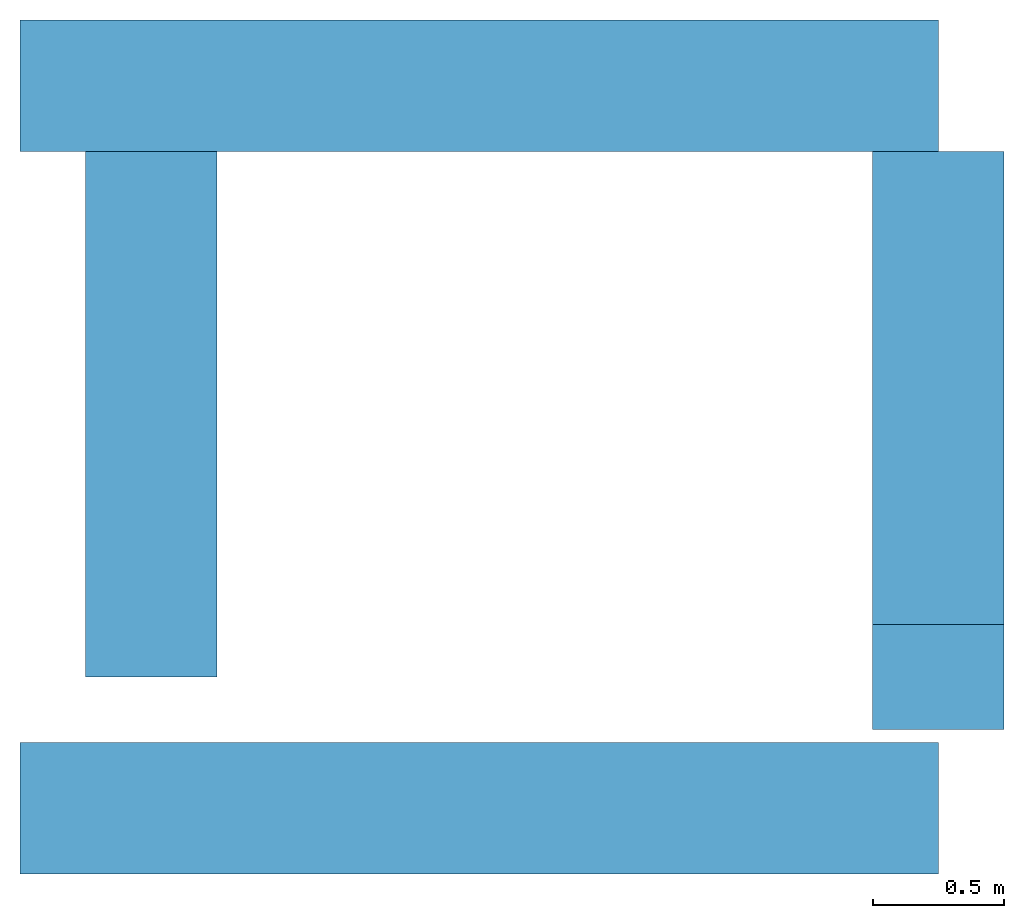
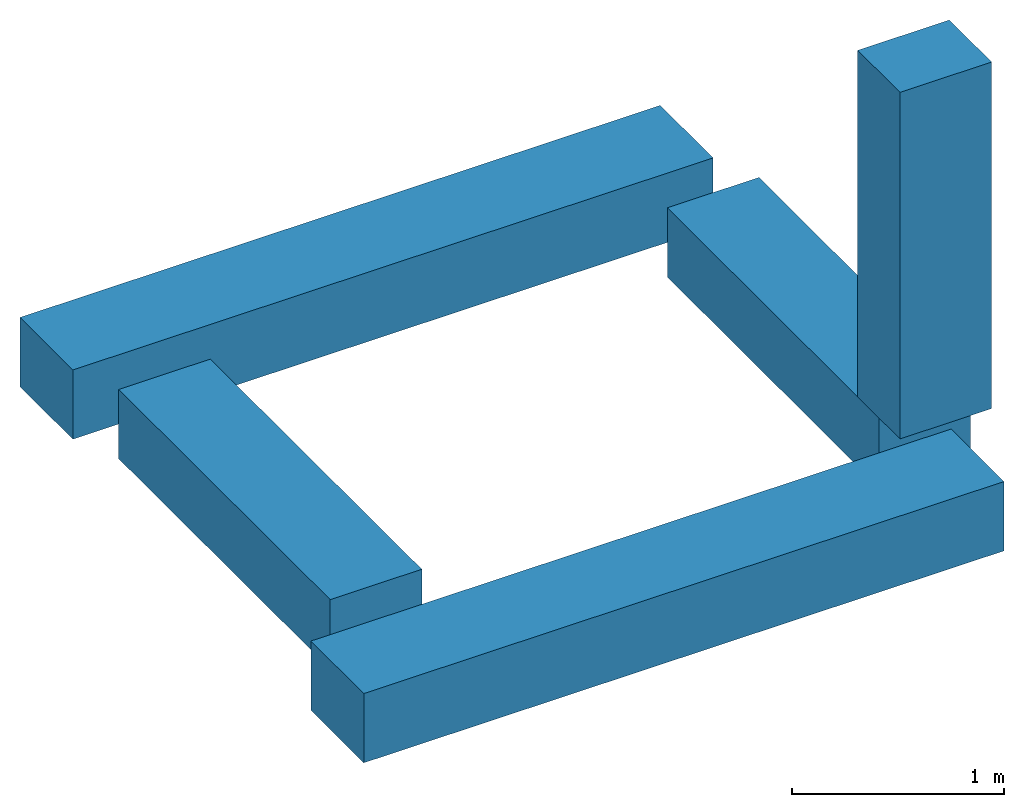
# One storey: 5 beams.
"""IFC4 building model written with IfcOpenShell, lengths in metres."""

from ifc_helpers import new_model, entity, si_unit, converted_unit, frame, frame_2d, origin_with_axes, place, context, subcontext, project, spatial, rectangle, extrude, material, material_profile, profile_set, profile_usage, type_object, element, save


model = new_model("IFC4")

# Units and contexts
model_context = context("Model", 3, precision=1e-05, world=origin_with_axes())
plan_context = context("Plan", 2, precision=1e-05, world=frame_2d((0.0, 0.0, 0.0), x_axis=(1.0, 0.0, 0.0)))
body_context = subcontext(model_context, "Body", "Model", "MODEL_VIEW")
ifc_project = project(units=[si_unit("LENGTHUNIT", "METRE"), converted_unit("PLANEANGLEUNIT", "degree", entity("IfcReal", 0.0174532925199433), si_unit("PLANEANGLEUNIT", "RADIAN"), dimensions=[0, 0, 0, 0, 0, 0, 0]), si_unit("AREAUNIT", "SQUARE_METRE"), si_unit("VOLUMEUNIT", "CUBIC_METRE")], contexts=[model_context, plan_context])

# Site, building, storey
site_placement = place(None, origin_with_axes())
site = spatial("IfcSite", under=ifc_project, at=site_placement)
building_placement = place(site_placement, origin_with_axes())
building = spatial("IfcBuilding", under=site, at=building_placement, Name="Building")
storey_placement = place(building_placement, origin_with_axes())
storey = spatial("IfcBuildingStorey", under=building, at=storey_placement, Name="Storey")

# Beams
ifc_material = material(Name="vuren")
ifc_material_profile = material_profile(ifc_material, rectangle(XDim=0.5, YDim=0.400000005960464))
ifc_profile_set = profile_set([ifc_material_profile])
ifc_profile_usage_1 = profile_usage(ifc_profile_set)
beam_type = type_object("IfcBeamType", Name="balk", PredefinedType="BEAM", material=ifc_profile_set)
beam_1_placement = place(storey_placement, frame((2.18557172360079e-09, -0.250000059604645, -0.200000002980232), z_axis=(1.0, 4.37113882867379e-08, -4.37113882867379e-08), x_axis=(-4.37113882867379e-08, 1.0, 0.0)))
element("IfcBeam", 1, at=beam_1_placement, inside=storey, type_object=beam_type, material=ifc_profile_usage_1, Name="Beam", context=body_context, shape_type="SweptSolid", body=[
    extrude(rectangle(XDim=0.5, YDim=0.400000005960464), None, (0.0, 0.0, 1.0), 3.49483203887939),
])
ifc_profile_usage_2 = profile_usage(ifc_profile_set)
beam_2_placement = place(storey_placement, frame((0.499999970197678, 0.250000149011612, -0.200000032782555), z_axis=(-3.89414367418794e-07, 1.0, -1.62920684942947e-07), x_axis=(-1.0, -3.89414367418794e-07, -7.36919087627715e-15)))
element("IfcBeam", 2, at=beam_2_placement, inside=storey, type_object=beam_type, material=ifc_profile_usage_2, Name="Beam", context=body_context, shape_type="SweptSolid", body=[
    extrude(rectangle(XDim=0.5, YDim=0.400000005960464), None, (0.0, 0.0, 1.0), 2.0),
])
ifc_profile_usage_3 = profile_usage(ifc_profile_set)
beam_3_placement = place(storey_placement, frame((3.49483203887939, 0.250000029802322, -0.200000151991844), z_axis=(-3.89414367418794e-07, 1.0, -1.62920684942947e-07), x_axis=(-1.0, -3.89414367418794e-07, -1.00485898695359e-14)))
element("IfcBeam", 3, at=beam_3_placement, inside=storey, type_object=beam_type, material=ifc_profile_usage_3, Name="Beam", context=body_context, shape_type="SweptSolid", body=[
    extrude(rectangle(XDim=0.5, YDim=0.400000005960464), None, (0.0, 0.0, 1.0), 2.0),
])
ifc_profile_usage_4 = profile_usage(ifc_profile_set)
beam_4_placement = place(storey_placement, frame((3.49483203887939, 0.250000089406967, 0.0), z_axis=(0.0, 0.0, 1.0), x_axis=(1.0, 0.0, 0.0)))
element("IfcBeam", 4, at=beam_4_placement, inside=storey, type_object=beam_type, material=ifc_profile_usage_4, Name="Beam", context=body_context, shape_type="SweptSolid", body=[
    extrude(rectangle(XDim=0.5, YDim=0.400000005960464), None, (0.0, 0.0, 1.0), 2.0),
])
ifc_profile_usage_5 = profile_usage(ifc_profile_set)
beam_5_placement = place(storey_placement, frame((-8.34465026855469e-07, 2.5, -3.22089022120053e-07), z_axis=(1.0, 4.37113882867379e-08, -4.37113882867379e-08), x_axis=(-4.37113882867379e-08, 1.0, 0.0)))
element("IfcBeam", 5, at=beam_5_placement, inside=storey, type_object=beam_type, material=ifc_profile_usage_5, Name="Beam", context=body_context, shape_type="SweptSolid", body=[
    extrude(rectangle(XDim=0.5, YDim=0.400000005960464), None, (0.0, 0.0, 1.0), 3.49483203887939),
])

save(model, "model.ifc")
